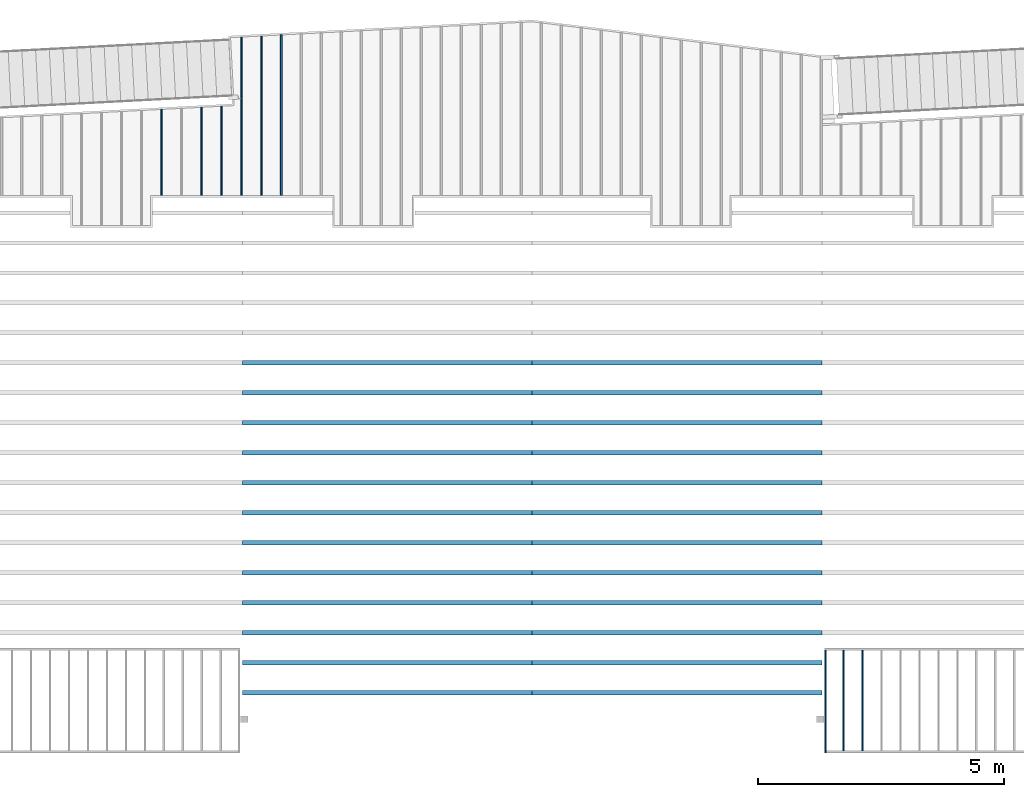
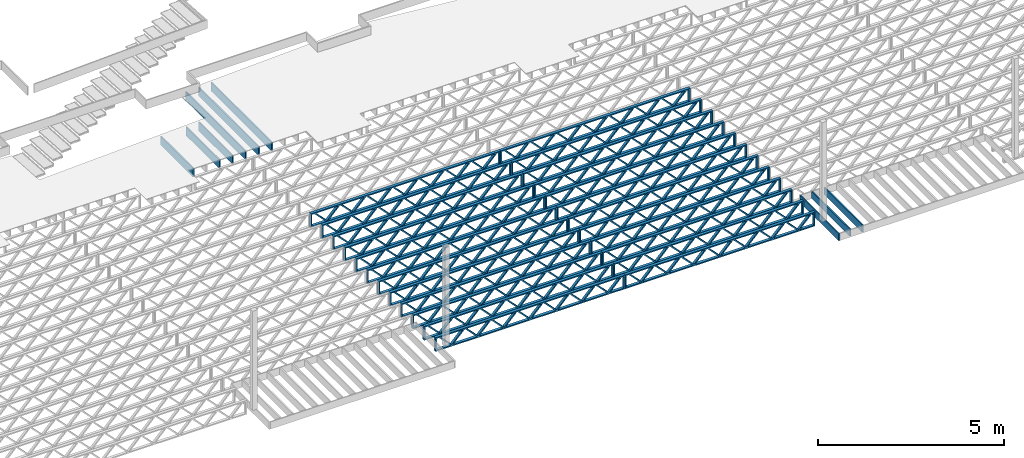
# One storey, part 6 of 23: 33 beams, 4 elements without a shape of their own.
"""IFC4 building model written with IfcOpenShell, lengths in feet."""

from ifc_helpers import new_model, entity, si_unit, converted_unit, derived_unit, direction, frame, frame_2d, origin, origin_2d_with_axis, place, context, subcontext, project, spatial, rectangle, extrude, source, transform, mapped, material, material_profile, profile_set, profile_usage, type_object, type_shapes, element, aggregate, save


model = new_model("IFC4")

# Units and contexts
model_context_1 = context("Model", 3, precision=0.0001, world=origin(), true_north=direction((6.12303176911189e-17, 1.0)))
model_context_2 = context("Model", 3, precision=0.0001, world=origin(), true_north=direction((6.12303176911189e-17, 1.0)))
body_context = subcontext(model_context_2, "Body", "Model", "MODEL_VIEW")
ifc_project = project(units=[converted_unit("LENGTHUNIT", "FOOT", entity("IfcRatioMeasure", 0.3048), si_unit("LENGTHUNIT", "METRE"), dimensions=[1, 0, 0, 0, 0, 0, 0]), converted_unit("AREAUNIT", "SQUARE FOOT", entity("IfcRatioMeasure", 0.09290304), si_unit("AREAUNIT", "SQUARE_METRE"), dimensions=[2, 0, 0, 0, 0, 0, 0]), converted_unit("VOLUMEUNIT", "CUBIC FOOT", entity("IfcRatioMeasure", 0.028316846592), si_unit("VOLUMEUNIT", "CUBIC_METRE"), dimensions=[3, 0, 0, 0, 0, 0, 0]), converted_unit("PLANEANGLEUNIT", "DEGREE", entity("IfcRatioMeasure", 0.0174532925199433), si_unit("PLANEANGLEUNIT", "RADIAN"), dimensions=[0, 0, 0, 0, 0, 0, 0]), si_unit("MASSUNIT", "GRAM", prefix="KILO"), derived_unit("MASSDENSITYUNIT", [(si_unit("MASSUNIT", "GRAM", prefix="KILO"), 1), (si_unit("LENGTHUNIT", "METRE"), -3)]), derived_unit("MOMENTOFINERTIAUNIT", [(si_unit("LENGTHUNIT", "METRE"), 4)]), si_unit("TIMEUNIT", "SECOND"), si_unit("FREQUENCYUNIT", "HERTZ"), si_unit("THERMODYNAMICTEMPERATUREUNIT", "DEGREE_CELSIUS"), derived_unit("THERMALTRANSMITTANCEUNIT", [(si_unit("MASSUNIT", "GRAM", prefix="KILO"), 1), (si_unit("THERMODYNAMICTEMPERATUREUNIT", "KELVIN"), -1), (si_unit("TIMEUNIT", "SECOND"), -3)]), derived_unit("VOLUMETRICFLOWRATEUNIT", [(si_unit("LENGTHUNIT", "METRE"), 3), (si_unit("TIMEUNIT", "SECOND"), -1)]), si_unit("ELECTRICCURRENTUNIT", "AMPERE"), si_unit("ELECTRICVOLTAGEUNIT", "VOLT"), si_unit("POWERUNIT", "WATT"), si_unit("FORCEUNIT", "NEWTON"), si_unit("ILLUMINANCEUNIT", "LUX"), si_unit("LUMINOUSFLUXUNIT", "LUMEN"), si_unit("LUMINOUSINTENSITYUNIT", "CANDELA"), derived_unit("USERDEFINED", [(si_unit("MASSUNIT", "GRAM", prefix="KILO"), -1), (si_unit("LENGTHUNIT", "METRE"), -2), (si_unit("TIMEUNIT", "SECOND"), 3), (si_unit("LUMINOUSFLUXUNIT", "LUMEN"), 1)]), derived_unit("LINEARVELOCITYUNIT", [(si_unit("LENGTHUNIT", "METRE"), 1), (si_unit("TIMEUNIT", "SECOND"), -1)]), si_unit("PRESSUREUNIT", "PASCAL"), derived_unit("USERDEFINED", [(si_unit("LENGTHUNIT", "METRE"), -2), (si_unit("MASSUNIT", "GRAM", prefix="KILO"), 1), (si_unit("TIMEUNIT", "SECOND"), -2)]), derived_unit("LINEARFORCEUNIT", [(si_unit("MASSUNIT", "GRAM", prefix="KILO"), 1), (si_unit("LENGTHUNIT", "METRE"), 1), (si_unit("TIMEUNIT", "SECOND"), -2), (si_unit("LENGTHUNIT", "METRE"), -1)]), derived_unit("PLANARFORCEUNIT", [(si_unit("MASSUNIT", "GRAM", prefix="KILO"), 1), (si_unit("LENGTHUNIT", "METRE"), 1), (si_unit("TIMEUNIT", "SECOND"), -2), (si_unit("LENGTHUNIT", "METRE"), -2)])], contexts=[model_context_1])

# Site, building, storey
site_placement = place(None, origin())
site = spatial("IfcSite", under=ifc_project, at=site_placement, CompositionType="ELEMENT")
building_placement = place(site_placement, origin())
building = spatial("IfcBuilding", under=site, at=building_placement, CompositionType="ELEMENT")
storey_placement = place(building_placement, frame((0.0, 0.0, 10.8020833333333)))
storey = spatial("IfcBuildingStorey", under=building, at=storey_placement, Name="2ND FLOOR", CompositionType="ELEMENT", Elevation=10.8020833333333)

# Assembly, beams
assembly_1_placement = place(storey_placement, origin())
assembly_1 = element("IfcElementAssembly", 1, at=assembly_1_placement, inside=storey, Name="Structural Beam System:Structural Framing System", ObjectType="Structural Beam System:Structural Framing System", AssemblyPlace="NOTDEFINED", PredefinedType="BEAM_GRID")
ifc_material_1 = material(Category="Materials")
ifc_material_profile_1 = material_profile(ifc_material_1, rectangle(XDim=0.9375, YDim=0.125000000000011, at=origin_2d_with_axis()))
ifc_profile_set_1 = profile_set([ifc_material_profile_1])
ifc_profile_usage_1 = profile_usage(ifc_profile_set_1, cardinal=8)
beam_type_1 = type_object("IfcBeamType", PredefinedType="BEAM", material=ifc_profile_set_1)
shared_shape_1 = source(origin(), body_context, "Body", "SweptSolid", [
    extrude(rectangle(XDim=0.9375, YDim=0.125000000000011, at=origin_2d_with_axis()), frame((-5.35354820779077, 0.0, 0.0), z_axis=(1.0, 0.0, 0.0), x_axis=(0.0, 0.0, -1.0)), (0.0, 0.0, 1.0), 10.7070964155815),
])
type_shapes(beam_type_1, [shared_shape_1])
beam_1_placement = place(assembly_1_placement, frame((-219.800660485462, 964.382151090665, -0.729166666666744), z_axis=(0.0, 0.0, 1.0), x_axis=(0.0, 1.0, 0.0)))
beam_1 = element("IfcBeam", 2, at=beam_1_placement, type_object=beam_type_1, material=ifc_profile_usage_1, PredefinedType="BEAM", context=body_context, shape_type="MappedRepresentation", body=[
    mapped(shared_shape_1, transform((0.0, 0.0, 0.0), scale=1.0)),
])
ifc_profile_usage_2 = profile_usage(ifc_profile_set_1, cardinal=8)
beam_type_2 = type_object("IfcBeamType", PredefinedType="BEAM", material=ifc_profile_set_1)
shared_shape_2 = source(origin(), body_context, "Body", "SweptSolid", [
    extrude(rectangle(XDim=0.9375, YDim=0.125000000000011, at=origin_2d_with_axis()), frame((-5.31404394297266, 0.0, 0.0), z_axis=(1.0, 0.0, 0.0), x_axis=(0.0, 0.0, -1.0)), (0.0, 0.0, 1.0), 10.5622266281151),
])
type_shapes(beam_type_2, [shared_shape_2])
beam_2_placement = place(assembly_1_placement, frame((-222.467327152129, 964.342647459835, -0.729166666666744), z_axis=(0.0, 0.0, 1.0), x_axis=(0.0, 1.0, 0.0)))
beam_2 = element("IfcBeam", 3, at=beam_2_placement, type_object=beam_type_2, material=ifc_profile_usage_2, PredefinedType="BEAM", context=body_context, shape_type="MappedRepresentation", body=[
    mapped(shared_shape_2, transform((0.0, 0.0, 0.0), scale=1.0)),
])
ifc_profile_usage_3 = profile_usage(ifc_profile_set_1, cardinal=8)
beam_type_3 = type_object("IfcBeamType", PredefinedType="BEAM", material=ifc_profile_set_1)
shared_shape_3 = source(origin(), body_context, "Body", "SweptSolid", [
    extrude(rectangle(XDim=0.9375, YDim=0.125000000000011, at=origin_2d_with_axis()), frame((-2.93892397223317, 0.0, 0.0), z_axis=(1.0, 0.0, 0.0), x_axis=(0.0, 0.0, -1.0)), (0.0, 0.0, 1.0), 5.87784794446634),
])
type_shapes(beam_type_3, [shared_shape_3])
beam_3_placement = place(assembly_1_placement, frame((-225.133993818795, 961.967528122797, -0.729166666666744), z_axis=(0.0, 0.0, 1.0), x_axis=(0.0, 1.0, 0.0)))
beam_3 = element("IfcBeam", 4, at=beam_3_placement, type_object=beam_type_3, material=ifc_profile_usage_3, PredefinedType="BEAM", context=body_context, shape_type="MappedRepresentation", body=[
    mapped(shared_shape_3, transform((0.0, 0.0, 0.0), scale=1.0)),
])

assembly_2_placement = place(storey_placement, origin())
assembly_2 = element("IfcElementAssembly", 5, at=assembly_2_placement, inside=storey, Name="Structural Beam System:Structural Framing System", ObjectType="Structural Beam System:Structural Framing System", AssemblyPlace="NOTDEFINED", PredefinedType="BEAM_GRID")
ifc_material_2 = material(Name="WOOD TRUSS", Category="Materials")
ifc_material_profile_2 = material_profile(ifc_material_2, rectangle(XDim=1.73473973950632, YDim=0.125, at=frame_2d((-1.11022302462516e-16, 8.32667268468867e-17), x_axis=(1.0, 0.0))))
ifc_material_profile_3 = material_profile(ifc_material_2, rectangle(XDim=1.73473973950633, YDim=0.125, at=frame_2d((-1.11022302462516e-16, 8.32667268468867e-17), x_axis=(1.0, 0.0))))
ifc_material_profile_4 = material_profile(ifc_material_2, rectangle(XDim=1.73473973950632, YDim=0.125, at=frame_2d((-5.55111512312578e-17, 1.38777878078145e-16), x_axis=(1.0, 0.0))))
ifc_material_profile_5 = material_profile(ifc_material_2, rectangle(XDim=1.73473973950633, YDim=0.125, at=frame_2d((-1.11022302462516e-16, 8.32667268468867e-17), x_axis=(1.0, 0.0))))
ifc_material_profile_6 = material_profile(ifc_material_2, rectangle(XDim=1.73473973950632, YDim=0.125, at=frame_2d((-1.11022302462516e-16, 8.32667268468867e-17), x_axis=(1.0, 0.0))))
ifc_material_profile_7 = material_profile(ifc_material_2, rectangle(XDim=1.73473973950633, YDim=0.125, at=frame_2d((-2.77555756156289e-16, 3.05311331771918e-16), x_axis=(1.0, 0.0))))
ifc_material_profile_8 = material_profile(ifc_material_2, rectangle(XDim=1.73473973950632, YDim=0.124999999999999, at=frame_2d((-3.88578058618805e-16, -2.4980018054066e-16), x_axis=(1.0, 0.0))))
ifc_material_profile_9 = material_profile(ifc_material_2, rectangle(XDim=1.73473973950633, YDim=0.125, at=frame_2d((2.77555756156289e-16, -3.05311331771918e-16), x_axis=(1.0, 0.0))))
ifc_material_profile_10 = material_profile(ifc_material_2, rectangle(XDim=1.73473973950632, YDim=0.124999999999999, at=frame_2d((-1.11022302462516e-16, 8.32667268468867e-17), x_axis=(1.0, 0.0))))
ifc_material_profile_11 = material_profile(ifc_material_2, rectangle(XDim=1.73473973950633, YDim=0.125, at=origin_2d_with_axis()))
ifc_material_profile_12 = material_profile(ifc_material_2, rectangle(XDim=0.124999999999982, YDim=0.291666666666668, at=origin_2d_with_axis()))
ifc_material_profile_13 = material_profile(ifc_material_2, rectangle(XDim=0.124999999999932, YDim=0.291666666666664, at=origin_2d_with_axis()))
ifc_material_profile_14 = material_profile(ifc_material_2, rectangle(XDim=1.25000000000002, YDim=0.29166666666667, at=origin_2d_with_axis()))
ifc_material_profile_15 = material_profile(ifc_material_2, rectangle(XDim=1.25000000000004, YDim=0.291666666666667, at=origin_2d_with_axis()))
ifc_profile_set_2 = profile_set([ifc_material_profile_2, ifc_material_profile_3, ifc_material_profile_4, ifc_material_profile_5, ifc_material_profile_6, ifc_material_profile_7, ifc_material_profile_8, ifc_material_profile_9, ifc_material_profile_10, ifc_material_profile_11, ifc_material_profile_12, ifc_material_profile_13, ifc_material_profile_14, ifc_material_profile_15])
ifc_profile_usage_4 = profile_usage(ifc_profile_set_2, cardinal=8)
beam_type_4 = type_object("IfcBeamType", PredefinedType="BEAM", material=ifc_profile_set_2)
shared_shape_4 = source(origin(), body_context, "Body", "SweptSolid", [
    extrude(rectangle(XDim=1.73473973950632, YDim=0.124999999999999, at=frame_2d((5.55111512312578e-16, 7.21644966006352e-16), x_axis=(1.0, 0.0))), frame((5.95847627016997, -0.145833333333334, 0.0), z_axis=(0.0, 1.0, 0.0), x_axis=(0.693383046997606, 0.0, 0.720569184836762)), (0.0, 0.0, 1.0), 0.291666666666667),
    extrude(rectangle(XDim=1.73473973950633, YDim=0.125, at=origin_2d_with_axis()), frame((4.7081903964967, -0.145833333333334, 0.0), z_axis=(0.0, 1.0, 0.0), x_axis=(0.69338304699761, 0.0, -0.720569184836758)), (0.0, 0.0, 1.0), 0.291666666666666),
    extrude(rectangle(XDim=1.73473973950632, YDim=0.125, at=frame_2d((2.22044604925031e-16, 3.88578058618805e-16), x_axis=(1.0, 0.0))), frame((3.29180960350347, -0.145833333333334, 0.0), z_axis=(0.0, 1.0, 0.0), x_axis=(0.693383046997606, 0.0, 0.720569184836762)), (0.0, 0.0, 1.0), 0.291666666666667),
    extrude(rectangle(XDim=1.73473973950633, YDim=0.125, at=frame_2d((1.11022302462516e-16, -8.32667268468867e-17), x_axis=(1.0, 0.0))), frame((2.0415237298302, -0.145833333333334, 0.0), z_axis=(0.0, 1.0, 0.0), x_axis=(0.69338304699761, 0.0, -0.720569184836758)), (0.0, 0.0, 1.0), 0.291666666666667),
    extrude(rectangle(XDim=1.73473973950632, YDim=0.125, at=frame_2d((-5.55111512312578e-17, 1.38777878078145e-16), x_axis=(1.0, 0.0))), frame((0.625142936836964, -0.145833333333334, 0.0), z_axis=(0.0, 1.0, 0.0), x_axis=(0.693383046997606, 0.0, 0.720569184836762)), (0.0, 0.0, 1.0), 0.291666666666667),
    extrude(rectangle(XDim=1.73473973950633, YDim=0.125, at=frame_2d((-1.11022302462516e-16, 8.32667268468867e-17), x_axis=(1.0, 0.0))), frame((-0.625142936836306, -0.145833333333334, 0.0), z_axis=(0.0, 1.0, 0.0), x_axis=(0.69338304699761, 0.0, -0.720569184836758)), (0.0, 0.0, 1.0), 0.291666666666667),
    extrude(rectangle(XDim=1.73473973950632, YDim=0.125, at=frame_2d((-1.11022302462516e-16, 8.32667268468867e-17), x_axis=(1.0, 0.0))), frame((-2.04152372982954, -0.145833333333334, 0.0), z_axis=(0.0, 1.0, 0.0), x_axis=(0.693383046997606, 0.0, 0.720569184836762)), (0.0, 0.0, 1.0), 0.291666666666667),
    extrude(rectangle(XDim=1.73473973950633, YDim=0.125, at=origin_2d_with_axis()), frame((-3.29180960350281, -0.145833333333334, 0.0), z_axis=(0.0, 1.0, 0.0), x_axis=(0.69338304699761, 0.0, -0.720569184836758)), (0.0, 0.0, 1.0), 0.291666666666667),
    extrude(rectangle(XDim=1.73473973950632, YDim=0.124999999999999, at=frame_2d((-1.11022302462516e-16, 8.32667268468867e-17), x_axis=(1.0, 0.0))), frame((-4.70819039649604, -0.145833333333334, 0.0), z_axis=(0.0, 1.0, 0.0), x_axis=(0.693383046997606, 0.0, 0.720569184836762)), (0.0, 0.0, 1.0), 0.291666666666667),
    extrude(rectangle(XDim=1.73473973950633, YDim=0.125, at=frame_2d((-5.55111512312578e-16, 6.38378239159465e-16), x_axis=(1.0, 0.0))), frame((-5.95847627016931, -0.145833333333334, 0.0), z_axis=(0.0, 1.0, 0.0), x_axis=(0.69338304699761, 0.0, -0.720569184836758)), (0.0, 0.0, 1.0), 0.291666666666666),
    extrude(rectangle(XDim=1.73473973950632, YDim=0.125, at=frame_2d((-7.21644966006352e-16, -5.82867087928207e-16), x_axis=(1.0, 0.0))), frame((8.62514293683647, -0.145833333333334, 0.0), z_axis=(0.0, 1.0, 0.0), x_axis=(0.693383046997607, 0.0, 0.720569184836761)), (0.0, 0.0, 1.0), 0.291666666666667),
    extrude(rectangle(XDim=1.73473973950633, YDim=0.125, at=origin_2d_with_axis()), frame((7.3748570631632, -0.145833333333334, 0.0), z_axis=(0.0, 1.0, 0.0), x_axis=(0.69338304699761, 0.0, -0.720569184836758)), (0.0, 0.0, 1.0), 0.291666666666666),
    extrude(rectangle(XDim=1.73473973950632, YDim=0.124999999999999, at=frame_2d((-1.11022302462516e-16, 8.32667268468867e-17), x_axis=(1.0, 0.0))), frame((-7.37485706316255, -0.145833333333334, 0.0), z_axis=(0.0, 1.0, 0.0), x_axis=(0.693383046997606, 0.0, 0.720569184836762)), (0.0, 0.0, 1.0), 0.291666666666667),
    extrude(rectangle(XDim=1.73473973950633, YDim=0.125, at=origin_2d_with_axis()), frame((-8.62514293683582, -0.145833333333334, 0.0), z_axis=(0.0, 1.0, 0.0), x_axis=(0.69338304699761, 0.0, -0.720569184836758)), (0.0, 0.0, 1.0), 0.291666666666666),
    extrude(rectangle(XDim=0.124999999999982, YDim=0.291666666666668, at=origin_2d_with_axis()), frame((-9.66666666666609, 0.0, 0.687500000000054), z_axis=(1.0, 0.0, 0.0), x_axis=(0.0, 0.0, -1.0)), (0.0, 0.0, 1.0), 19.3333333333322),
    extrude(rectangle(XDim=0.124999999999932, YDim=0.291666666666664, at=origin_2d_with_axis()), frame((-9.66666666666588, 0.0, -0.687499999999984), z_axis=(1.0, 0.0, 0.0), x_axis=(0.0, 0.0, -1.0)), (0.0, 0.0, 1.0), 19.333333333332),
    extrude(rectangle(XDim=1.25000000000002, YDim=0.29166666666667, at=origin_2d_with_axis()), frame((9.54166666666607, 0.0, 0.0), z_axis=(1.0, 0.0, 0.0), x_axis=(0.0, 0.0, -1.0)), (0.0, 0.0, 1.0), 0.12500000000002),
    extrude(rectangle(XDim=1.25000000000004, YDim=0.291666666666667, at=origin_2d_with_axis()), frame((-9.66666666666609, 0.0, 0.0), z_axis=(1.0, 0.0, 0.0), x_axis=(0.0, 0.0, -1.0)), (0.0, 0.0, 1.0), 0.125000000000023),
])
type_shapes(beam_type_4, [shared_shape_4])
beam_4_placement = place(assembly_2_placement, frame((-193.404827152229, 947.861934882651, -0.947916666666881)))
beam_4 = element("IfcBeam", 6, at=beam_4_placement, type_object=beam_type_4, material=ifc_profile_usage_4, PredefinedType="BEAM", context=body_context, shape_type="MappedRepresentation", body=[
    mapped(shared_shape_4, transform((0.0, 0.0, 0.0), scale=1.0)),
])
ifc_profile_usage_5 = profile_usage(ifc_profile_set_2, cardinal=8)
beam_5_placement = place(assembly_2_placement, frame((-193.404827152229, 945.861934882651, -0.947916666666881)))
beam_5 = element("IfcBeam", 7, at=beam_5_placement, type_object=beam_type_4, material=ifc_profile_usage_5, PredefinedType="BEAM", context=body_context, shape_type="MappedRepresentation", body=[
    mapped(shared_shape_4, transform((0.0, 0.0, 0.0), scale=1.0)),
])
ifc_profile_usage_6 = profile_usage(ifc_profile_set_2, cardinal=8)
beam_6_placement = place(assembly_2_placement, frame((-193.404827152229, 943.861934882651, -0.947916666666881)))
beam_6 = element("IfcBeam", 8, at=beam_6_placement, type_object=beam_type_4, material=ifc_profile_usage_6, PredefinedType="BEAM", context=body_context, shape_type="MappedRepresentation", body=[
    mapped(shared_shape_4, transform((0.0, 0.0, 0.0), scale=1.0)),
])
ifc_profile_usage_7 = profile_usage(ifc_profile_set_2, cardinal=8)
beam_7_placement = place(assembly_2_placement, frame((-193.404827152229, 941.861934882651, -0.947916666666881)))
beam_7 = element("IfcBeam", 9, at=beam_7_placement, type_object=beam_type_4, material=ifc_profile_usage_7, PredefinedType="BEAM", context=body_context, shape_type="MappedRepresentation", body=[
    mapped(shared_shape_4, transform((0.0, 0.0, 0.0), scale=1.0)),
])
ifc_profile_usage_8 = profile_usage(ifc_profile_set_2, cardinal=8)
beam_8_placement = place(assembly_2_placement, frame((-193.404827152229, 939.861934882651, -0.947916666666881)))
beam_8 = element("IfcBeam", 10, at=beam_8_placement, type_object=beam_type_4, material=ifc_profile_usage_8, PredefinedType="BEAM", context=body_context, shape_type="MappedRepresentation", body=[
    mapped(shared_shape_4, transform((0.0, 0.0, 0.0), scale=1.0)),
])
ifc_profile_usage_9 = profile_usage(ifc_profile_set_2, cardinal=8)
beam_9_placement = place(assembly_2_placement, frame((-193.404827152229, 937.861934882651, -0.947916666666881)))
beam_9 = element("IfcBeam", 11, at=beam_9_placement, type_object=beam_type_4, material=ifc_profile_usage_9, PredefinedType="BEAM", context=body_context, shape_type="MappedRepresentation", body=[
    mapped(shared_shape_4, transform((0.0, 0.0, 0.0), scale=1.0)),
])
ifc_profile_usage_10 = profile_usage(ifc_profile_set_2, cardinal=8)
beam_10_placement = place(assembly_2_placement, frame((-193.404827152229, 935.861934882651, -0.947916666666881)))
beam_10 = element("IfcBeam", 12, at=beam_10_placement, type_object=beam_type_4, material=ifc_profile_usage_10, PredefinedType="BEAM", context=body_context, shape_type="MappedRepresentation", body=[
    mapped(shared_shape_4, transform((0.0, 0.0, 0.0), scale=1.0)),
])
ifc_profile_usage_11 = profile_usage(ifc_profile_set_2, cardinal=8)
beam_11_placement = place(assembly_2_placement, frame((-193.404827152229, 933.861934882651, -0.947916666666881)))
beam_11 = element("IfcBeam", 13, at=beam_11_placement, type_object=beam_type_4, material=ifc_profile_usage_11, PredefinedType="BEAM", context=body_context, shape_type="MappedRepresentation", body=[
    mapped(shared_shape_4, transform((0.0, 0.0, 0.0), scale=1.0)),
])
ifc_profile_usage_12 = profile_usage(ifc_profile_set_2, cardinal=8)
beam_12_placement = place(assembly_2_placement, frame((-193.404827152229, 931.861934882651, -0.947916666666881)))
beam_12 = element("IfcBeam", 14, at=beam_12_placement, type_object=beam_type_4, material=ifc_profile_usage_12, PredefinedType="BEAM", context=body_context, shape_type="MappedRepresentation", body=[
    mapped(shared_shape_4, transform((0.0, 0.0, 0.0), scale=1.0)),
])
ifc_profile_usage_13 = profile_usage(ifc_profile_set_2, cardinal=8)
beam_13_placement = place(assembly_2_placement, frame((-193.404827152229, 929.861934882651, -0.947916666666881)))
beam_13 = element("IfcBeam", 15, at=beam_13_placement, type_object=beam_type_4, material=ifc_profile_usage_13, PredefinedType="BEAM", context=body_context, shape_type="MappedRepresentation", body=[
    mapped(shared_shape_4, transform((0.0, 0.0, 0.0), scale=1.0)),
])
ifc_profile_usage_14 = profile_usage(ifc_profile_set_2, cardinal=8)
beam_14_placement = place(assembly_2_placement, frame((-193.404827152229, 927.861934882651, -0.947916666666881)))
beam_14 = element("IfcBeam", 16, at=beam_14_placement, type_object=beam_type_4, material=ifc_profile_usage_14, PredefinedType="BEAM", context=body_context, shape_type="MappedRepresentation", body=[
    mapped(shared_shape_4, transform((0.0, 0.0, 0.0), scale=1.0)),
])
ifc_profile_usage_15 = profile_usage(ifc_profile_set_2, cardinal=8)
beam_15_placement = place(assembly_2_placement, frame((-193.404827152229, 925.861934882651, -0.947916666666881)))
beam_15 = element("IfcBeam", 17, at=beam_15_placement, type_object=beam_type_4, material=ifc_profile_usage_15, PredefinedType="BEAM", context=body_context, shape_type="MappedRepresentation", body=[
    mapped(shared_shape_4, transform((0.0, 0.0, 0.0), scale=1.0)),
])
aggregate(assembly_2, [beam_4, beam_5, beam_6, beam_7, beam_8, beam_9, beam_10, beam_11, beam_12, beam_13, beam_14, beam_15])

assembly_3_placement = place(storey_placement, origin())
assembly_3 = element("IfcElementAssembly", 18, at=assembly_3_placement, inside=storey, Name="Structural Beam System:Structural Framing System", ObjectType="Structural Beam System:Structural Framing System", AssemblyPlace="NOTDEFINED", PredefinedType="BEAM_GRID")
ifc_profile_usage_16 = profile_usage(ifc_profile_set_2, cardinal=8)
beam_16_placement = place(assembly_3_placement, frame((-212.738160485495, 947.861934882651, -0.947916666666881), z_axis=(0.0, 0.0, 1.0), x_axis=(-1.0, 0.0, 0.0)))
beam_16 = element("IfcBeam", 19, at=beam_16_placement, type_object=beam_type_4, material=ifc_profile_usage_16, PredefinedType="BEAM", context=body_context, shape_type="MappedRepresentation", body=[
    mapped(shared_shape_4, transform((0.0, 0.0, 0.0), scale=1.0)),
])
ifc_profile_usage_17 = profile_usage(ifc_profile_set_2, cardinal=8)
beam_17_placement = place(assembly_3_placement, frame((-212.738160485495, 945.861934882651, -0.947916666666881), z_axis=(0.0, 0.0, 1.0), x_axis=(-1.0, 0.0, 0.0)))
beam_17 = element("IfcBeam", 20, at=beam_17_placement, type_object=beam_type_4, material=ifc_profile_usage_17, PredefinedType="BEAM", context=body_context, shape_type="MappedRepresentation", body=[
    mapped(shared_shape_4, transform((0.0, 0.0, 0.0), scale=1.0)),
])
ifc_profile_usage_18 = profile_usage(ifc_profile_set_2, cardinal=8)
beam_18_placement = place(assembly_3_placement, frame((-212.738160485495, 943.861934882651, -0.947916666666881), z_axis=(0.0, 0.0, 1.0), x_axis=(-1.0, 0.0, 0.0)))
beam_18 = element("IfcBeam", 21, at=beam_18_placement, type_object=beam_type_4, material=ifc_profile_usage_18, PredefinedType="BEAM", context=body_context, shape_type="MappedRepresentation", body=[
    mapped(shared_shape_4, transform((0.0, 0.0, 0.0), scale=1.0)),
])
ifc_profile_usage_19 = profile_usage(ifc_profile_set_2, cardinal=8)
beam_19_placement = place(assembly_3_placement, frame((-212.738160485495, 941.861934882651, -0.947916666666881), z_axis=(0.0, 0.0, 1.0), x_axis=(-1.0, 0.0, 0.0)))
beam_19 = element("IfcBeam", 22, at=beam_19_placement, type_object=beam_type_4, material=ifc_profile_usage_19, PredefinedType="BEAM", context=body_context, shape_type="MappedRepresentation", body=[
    mapped(shared_shape_4, transform((0.0, 0.0, 0.0), scale=1.0)),
])
ifc_profile_usage_20 = profile_usage(ifc_profile_set_2, cardinal=8)
beam_20_placement = place(assembly_3_placement, frame((-212.738160485495, 939.861934882651, -0.947916666666881), z_axis=(0.0, 0.0, 1.0), x_axis=(-1.0, 0.0, 0.0)))
beam_20 = element("IfcBeam", 23, at=beam_20_placement, type_object=beam_type_4, material=ifc_profile_usage_20, PredefinedType="BEAM", context=body_context, shape_type="MappedRepresentation", body=[
    mapped(shared_shape_4, transform((0.0, 0.0, 0.0), scale=1.0)),
])
ifc_profile_usage_21 = profile_usage(ifc_profile_set_2, cardinal=8)
beam_21_placement = place(assembly_3_placement, frame((-212.738160485495, 937.861934882651, -0.947916666666881), z_axis=(0.0, 0.0, 1.0), x_axis=(-1.0, 0.0, 0.0)))
beam_21 = element("IfcBeam", 24, at=beam_21_placement, type_object=beam_type_4, material=ifc_profile_usage_21, PredefinedType="BEAM", context=body_context, shape_type="MappedRepresentation", body=[
    mapped(shared_shape_4, transform((0.0, 0.0, 0.0), scale=1.0)),
])
ifc_profile_usage_22 = profile_usage(ifc_profile_set_2, cardinal=8)
beam_22_placement = place(assembly_3_placement, frame((-212.738160485495, 935.861934882651, -0.947916666666881), z_axis=(0.0, 0.0, 1.0), x_axis=(-1.0, 0.0, 0.0)))
beam_22 = element("IfcBeam", 25, at=beam_22_placement, type_object=beam_type_4, material=ifc_profile_usage_22, PredefinedType="BEAM", context=body_context, shape_type="MappedRepresentation", body=[
    mapped(shared_shape_4, transform((0.0, 0.0, 0.0), scale=1.0)),
])
ifc_profile_usage_23 = profile_usage(ifc_profile_set_2, cardinal=8)
beam_23_placement = place(assembly_3_placement, frame((-212.738160485495, 933.861934882651, -0.947916666666881), z_axis=(0.0, 0.0, 1.0), x_axis=(-1.0, 0.0, 0.0)))
beam_23 = element("IfcBeam", 26, at=beam_23_placement, type_object=beam_type_4, material=ifc_profile_usage_23, PredefinedType="BEAM", context=body_context, shape_type="MappedRepresentation", body=[
    mapped(shared_shape_4, transform((0.0, 0.0, 0.0), scale=1.0)),
])
ifc_profile_usage_24 = profile_usage(ifc_profile_set_2, cardinal=8)
beam_24_placement = place(assembly_3_placement, frame((-212.738160485495, 931.861934882651, -0.947916666666881), z_axis=(0.0, 0.0, 1.0), x_axis=(-1.0, 0.0, 0.0)))
beam_24 = element("IfcBeam", 27, at=beam_24_placement, type_object=beam_type_4, material=ifc_profile_usage_24, PredefinedType="BEAM", context=body_context, shape_type="MappedRepresentation", body=[
    mapped(shared_shape_4, transform((0.0, 0.0, 0.0), scale=1.0)),
])
ifc_profile_usage_25 = profile_usage(ifc_profile_set_2, cardinal=8)
beam_25_placement = place(assembly_3_placement, frame((-212.738160485495, 929.861934882651, -0.947916666666881), z_axis=(0.0, 0.0, 1.0), x_axis=(-1.0, 0.0, 0.0)))
beam_25 = element("IfcBeam", 28, at=beam_25_placement, type_object=beam_type_4, material=ifc_profile_usage_25, PredefinedType="BEAM", context=body_context, shape_type="MappedRepresentation", body=[
    mapped(shared_shape_4, transform((0.0, 0.0, 0.0), scale=1.0)),
])
ifc_profile_usage_26 = profile_usage(ifc_profile_set_2, cardinal=8)
beam_26_placement = place(assembly_3_placement, frame((-212.738160485495, 927.861934882651, -0.947916666666881), z_axis=(0.0, 0.0, 1.0), x_axis=(-1.0, 0.0, 0.0)))
beam_26 = element("IfcBeam", 29, at=beam_26_placement, type_object=beam_type_4, material=ifc_profile_usage_26, PredefinedType="BEAM", context=body_context, shape_type="MappedRepresentation", body=[
    mapped(shared_shape_4, transform((0.0, 0.0, 0.0), scale=1.0)),
])
ifc_profile_usage_27 = profile_usage(ifc_profile_set_2, cardinal=8)
beam_27_placement = place(assembly_3_placement, frame((-212.738160485495, 925.861934882651, -0.947916666666881), z_axis=(0.0, 0.0, 1.0), x_axis=(-1.0, 0.0, 0.0)))
beam_27 = element("IfcBeam", 30, at=beam_27_placement, type_object=beam_type_4, material=ifc_profile_usage_27, PredefinedType="BEAM", context=body_context, shape_type="MappedRepresentation", body=[
    mapped(shared_shape_4, transform((0.0, 0.0, 0.0), scale=1.0)),
])
aggregate(assembly_3, [beam_16, beam_17, beam_18, beam_19, beam_20, beam_21, beam_22, beam_23, beam_24, beam_25, beam_26, beam_27])

assembly_4_placement = place(storey_placement, origin())
assembly_4 = element("IfcElementAssembly", 31, at=assembly_4_placement, inside=storey, Name="Structural Beam System:Structural Framing System", ObjectType="Structural Beam System:Structural Framing System", AssemblyPlace="NOTDEFINED", PredefinedType="BEAM_GRID")
ifc_material_profile_16 = material_profile(ifc_material_1, rectangle(XDim=0.770833333333333, YDim=0.124999999999994, at=frame_2d((-5.55111512312578e-17, 0.0), x_axis=(1.0, 0.0))))
ifc_profile_set_3 = profile_set([ifc_material_profile_16])
ifc_profile_usage_28 = profile_usage(ifc_profile_set_3, cardinal=8)
beam_type_5 = type_object("IfcBeamType", PredefinedType="BEAM", material=ifc_profile_set_3)
shared_shape_5 = source(origin(), body_context, "Body", "SweptSolid", [
    extrude(rectangle(XDim=0.770833333333333, YDim=0.124999999999994, at=frame_2d((-5.55111512312578e-17, 0.0), x_axis=(1.0, 0.0))), frame((-3.35416666666737, 0.0, 0.0), z_axis=(1.0, 0.0, 0.0), x_axis=(0.0, 0.0, -1.0)), (0.0, 0.0, 1.0), 6.70833333333462),
])
type_shapes(beam_type_5, [shared_shape_5])
beam_28_placement = place(assembly_4_placement, frame((-181.03772718933, 925.341101549318, -0.645833333333471), z_axis=(0.0, 0.0, 1.0), x_axis=(0.0, 1.0, 0.0)))
beam_28 = element("IfcBeam", 32, at=beam_28_placement, type_object=beam_type_5, material=ifc_profile_usage_28, PredefinedType="BEAM", context=body_context, shape_type="MappedRepresentation", body=[
    mapped(shared_shape_5, transform((0.0, 0.0, 0.0), scale=1.0)),
])
ifc_profile_usage_29 = profile_usage(ifc_profile_set_3, cardinal=8)
beam_29_placement = place(assembly_4_placement, frame((-182.304610869888, 925.341101549319, -0.645833333333471), z_axis=(0.0, 0.0, 1.0), x_axis=(0.0, 1.0, 0.0)))
beam_29 = element("IfcBeam", 33, at=beam_29_placement, type_object=beam_type_5, material=ifc_profile_usage_29, PredefinedType="BEAM", context=body_context, shape_type="MappedRepresentation", body=[
    mapped(shared_shape_5, transform((0.0, 0.0, 0.0), scale=1.0)),
])
aggregate(assembly_4, [beam_28, beam_29])

# Beam
ifc_profile_usage_30 = profile_usage(ifc_profile_set_3, cardinal=8)
beam_type_6 = type_object("IfcBeamType", PredefinedType="BEAM", material=ifc_profile_set_3)
shared_shape_6 = source(origin(), body_context, "Body", "SweptSolid", [
    extrude(rectangle(XDim=0.770833333333333, YDim=0.124999999999994, at=frame_2d((-5.55111512312578e-17, 0.0), x_axis=(1.0, 0.0))), frame((-3.47916666666737, 0.0, 0.0), z_axis=(1.0, 0.0, 0.0), x_axis=(0.0, 0.0, -1.0)), (0.0, 0.0, 1.0), 6.83333333333485),
])
type_shapes(beam_type_6, [shared_shape_6])
beam_30_placement = place(storey_placement, frame((-183.5089915739, 925.341101549319, -0.645833333333512), z_axis=(0.0, 0.0, 1.0), x_axis=(0.0, 1.0, 0.0)))
element("IfcBeam", 34, at=beam_30_placement, inside=storey, type_object=beam_type_6, material=ifc_profile_usage_30, PredefinedType="BEAM", context=body_context, shape_type="MappedRepresentation", body=[
    mapped(shared_shape_6, transform((0.0, 0.0, 0.0), scale=1.0)),
])

ifc_profile_usage_31 = profile_usage(ifc_profile_set_1, cardinal=8)
beam_type_7 = type_object("IfcBeamType", PredefinedType="BEAM", material=ifc_profile_set_1)
shared_shape_7 = source(origin(), body_context, "Body", "SweptSolid", [
    extrude(rectangle(XDim=0.9375, YDim=0.125000000000011, at=origin_2d_with_axis()), frame((-2.86904661608258, 0.0, 0.0), z_axis=(1.0, 0.0, 0.0), x_axis=(0.0, 0.0, -1.0)), (0.0, 0.0, 1.0), 5.73809323216517),
])
type_shapes(beam_type_7, [shared_shape_7])
beam_31_placement = place(assembly_1_placement, frame((-227.800660485462, 961.89765140086, -0.729166666666744), z_axis=(0.0, 0.0, 1.0), x_axis=(0.0, 1.0, 0.0)))
beam_31 = element("IfcBeam", 35, at=beam_31_placement, type_object=beam_type_7, material=ifc_profile_usage_31, PredefinedType="BEAM", context=body_context, shape_type="MappedRepresentation", body=[
    mapped(shared_shape_7, transform((0.0, 0.0, 0.0), scale=1.0)),
])

ifc_profile_usage_32 = profile_usage(ifc_profile_set_1, cardinal=8)
beam_type_8 = type_object("IfcBeamType", PredefinedType="BEAM", material=ifc_profile_set_1)
shared_shape_8 = source(origin(), body_context, "Body", "SweptSolid", [
    extrude(rectangle(XDim=0.9375, YDim=0.125000000000011, at=origin_2d_with_axis()), frame((-2.97386265030843, 0.0, 0.0), z_axis=(1.0, 0.0, 0.0), x_axis=(0.0, 0.0, -1.0)), (0.0, 0.0, 1.0), 5.94772530061687),
])
type_shapes(beam_type_8, [shared_shape_8])
beam_32_placement = place(assembly_1_placement, frame((-223.800660485462, 962.002466483765, -0.729166666666744), z_axis=(0.0, 0.0, 1.0), x_axis=(0.0, 1.0, 0.0)))
beam_32 = element("IfcBeam", 36, at=beam_32_placement, type_object=beam_type_8, material=ifc_profile_usage_32, PredefinedType="BEAM", context=body_context, shape_type="MappedRepresentation", body=[
    mapped(shared_shape_8, transform((0.0, 0.0, 0.0), scale=1.0)),
])

ifc_profile_usage_33 = profile_usage(ifc_profile_set_1, cardinal=8)
beam_type_9 = type_object("IfcBeamType", PredefinedType="BEAM", material=ifc_profile_set_1)
shared_shape_9 = source(origin(), body_context, "Body", "SweptSolid", [
    extrude(rectangle(XDim=0.9375, YDim=0.125000000000011, at=origin_2d_with_axis()), frame((-5.31880329353191, 0.0, 0.0), z_axis=(1.0, 0.0, 0.0), x_axis=(0.0, 0.0, -1.0)), (0.0, 0.0, 1.0), 10.6376065870638),
])
type_shapes(beam_type_9, [shared_shape_9])
beam_33_placement = place(assembly_1_placement, frame((-221.133993818795, 964.3474064934, -0.729166666666744), z_axis=(0.0, 0.0, 1.0), x_axis=(0.0, 1.0, 0.0)))
beam_33 = element("IfcBeam", 37, at=beam_33_placement, type_object=beam_type_9, material=ifc_profile_usage_33, PredefinedType="BEAM", context=body_context, shape_type="MappedRepresentation", body=[
    mapped(shared_shape_9, transform((0.0, 0.0, 0.0), scale=1.0)),
])

aggregate(assembly_1, [beam_1, beam_2, beam_3, beam_31, beam_32, beam_33])

save(model, "model.ifc")
